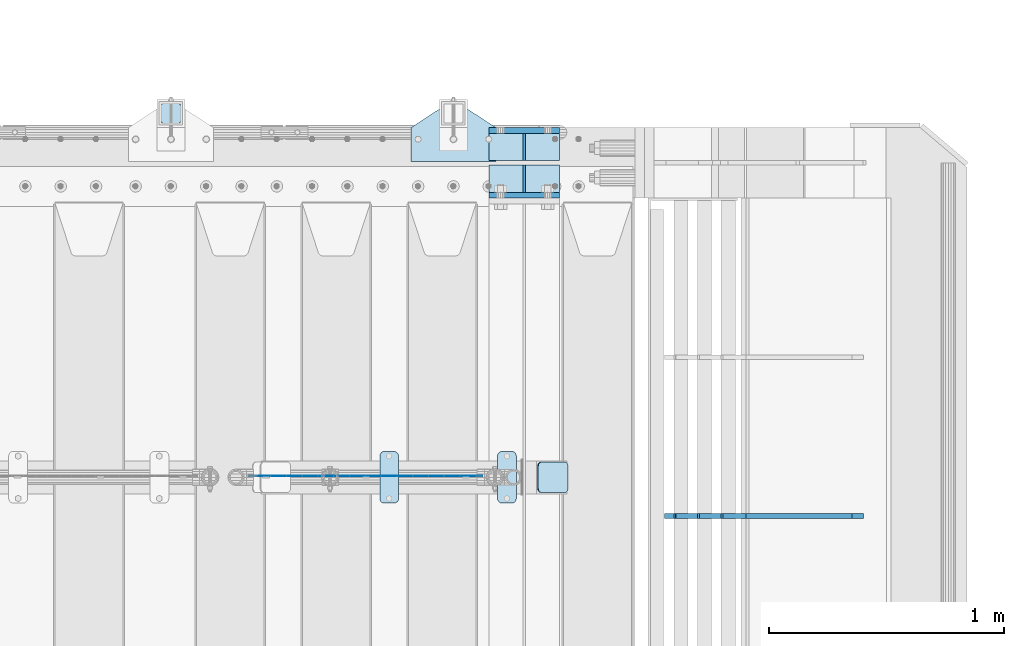
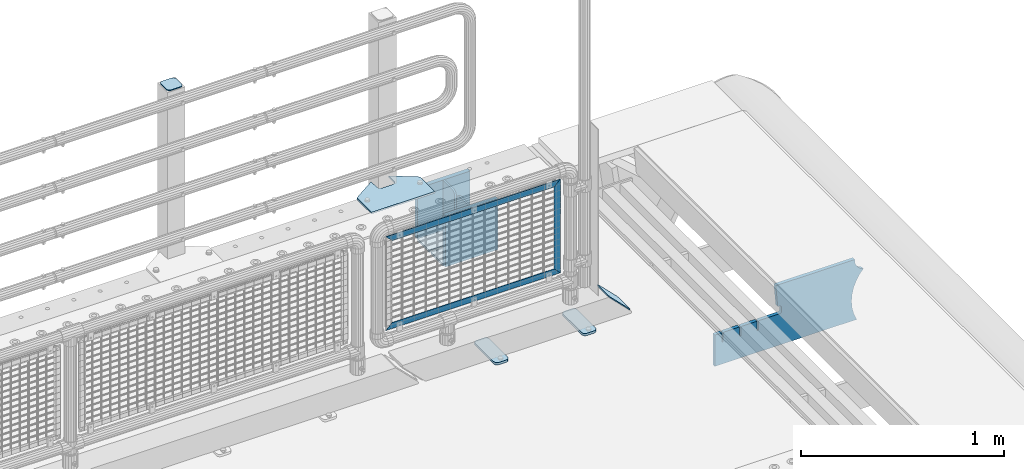
# One storey, part 251 of 270: 15 plates.
"""IFC2X3 building model written with IfcOpenShell, lengths in millimetres."""

from ifc_helpers import new_model, si_unit, frame, origin_with_axes, place, context, subcontext, project, spatial, faceted_brep, material, type_object, element, save


model = new_model("IFC2X3")

# Units and contexts
model_context = context("Model", 3, precision=1e-05, world=origin_with_axes())
body_context = subcontext(model_context, "Body", "Model", "MODEL_VIEW")
ifc_project = project(units=[si_unit("LENGTHUNIT", "METRE", prefix="MILLI"), si_unit("AREAUNIT", "SQUARE_METRE"), si_unit("VOLUMEUNIT", "CUBIC_METRE"), si_unit("MASSUNIT", "GRAM", prefix="KILO"), si_unit("TIMEUNIT", "SECOND"), si_unit("PLANEANGLEUNIT", "RADIAN"), si_unit("SOLIDANGLEUNIT", "STERADIAN"), si_unit("THERMODYNAMICTEMPERATUREUNIT", "DEGREE_CELSIUS"), si_unit("LUMINOUSINTENSITYUNIT", "LUMEN")], contexts=[model_context])

# Site, building, storey
site_placement = place(None, origin_with_axes())
site = spatial("IfcSite", under=ifc_project, at=site_placement, CompositionType="ELEMENT")
building_placement = place(site_placement, origin_with_axes())
building = spatial("IfcBuilding", under=site, at=building_placement, Name="Standard", CompositionType="ELEMENT")
storey_placement = place(building_placement, origin_with_axes())
storey = spatial("IfcBuildingStorey", under=building, at=storey_placement, Name="Undefined", CompositionType="ELEMENT", Elevation=0.0)

# Plates
ifc_material_1 = material(Name="STEEL/S355N")
plate_type_1 = type_object("IfcPlateType", PredefinedType="NOTDEFINED")
for number, where, z_axis, x_axis in (
    (1, (19768.0, -14862.5, -339.99999999999), (0.0, 0.0, 1.0), (1.0, 0.0, 0.0)),
    (2, (19768.0, -15137.5, -339.99999999999), (0.0, 0.0, 1.0), (1.0, 0.0, 0.0)),
):
    element("IfcPlate", number, at=place(storey_placement, frame(where, z_axis=z_axis, x_axis=x_axis)), inside=storey, type_object=plate_type_1, material=ifc_material_1, context=body_context, shape_type="Brep", body=[
        faceted_brep([(0.0, -12.5, 0.0), (0.0, -12.5, 305.0), (0.0, 12.5, 305.0), (0.0, 12.5, 0.0), (300.0, -12.5, 305.0), (300.0, 12.5, 305.0), (300.0, -12.5, 0.0), (300.0, 12.5, 0.0)], [[[0, 1, 2, 3]], [[1, 4, 5, 2]], [[4, 6, 7, 5]], [[6, 0, 3, 7]], [[5, 7, 3, 2]], [[6, 4, 1, 0]]]),
    ])
plate_type_2 = type_object("IfcPlateType", PredefinedType="NOTDEFINED")
for number, where, z_axis, x_axis in (
    (3, (19768.0, -14990.75, -342.99999999999), (0.0, 1.0, 0.0), (1.0, 0.0, 0.0)),
    (4, (19768.0, -15009.25, -342.99999999999), (0.0, -1.0, 0.0), (1.0, 0.0, 0.0)),
):
    element("IfcPlate", number, at=place(storey_placement, frame(where, z_axis=z_axis, x_axis=x_axis)), inside=storey, type_object=plate_type_2, material=ifc_material_1, context=body_context, shape_type="Brep", body=[
        faceted_brep([(0.0, -7.0, 0.0), (0.0, -7.0, 115.75), (0.0, 7.0, 115.75), (0.0, 7.0, 0.0), (300.0, -7.0, 115.75), (300.0, 7.0, 115.75), (300.0, -7.0, 0.0), (300.0, 7.0, 0.0)], [[[0, 1, 2, 3]], [[1, 4, 5, 2]], [[4, 6, 7, 5]], [[6, 0, 3, 7]], [[5, 7, 3, 2]], [[6, 4, 1, 0]]]),
    ])
plate_type_3 = type_object("IfcPlateType", PredefinedType="NOTDEFINED")
for number, where, z_axis, x_axis in (
    (5, (19918.0, -14990.75, -34.9999999999899), (0.0, 0.0, -1.0), (0.0, 1.0, 0.0)),
    (6, (19918.0, -15009.25, -34.9999999999899), (0.0, 0.0, -1.0), (0.0, -1.0, 0.0)),
):
    element("IfcPlate", number, at=place(storey_placement, frame(where, z_axis=z_axis, x_axis=x_axis)), inside=storey, type_object=plate_type_3, material=ifc_material_1, context=body_context, shape_type="Brep", body=[
        faceted_brep([(0.0, -5.0, 30.0), (0.0, -5.0, 301.0), (0.0, 5.0, 301.0), (0.0, 5.0, 30.0), (115.75, -5.0, 301.0), (115.75, 5.0, 301.0), (115.75, -5.0, 0.0), (115.75, 5.0, 0.0), (30.0, -5.0, 0.0), (30.0, 5.0, 0.0), (24.7905546699913, -5.0, 0.455767409633758), (24.7905546699913, 5.0, 0.455767409633758), (19.7393957002314, -5.0, 1.80922137642275), (19.7393957002314, 5.0, 1.80922137642275), (15.0, -5.0, 4.01923788646684), (15.0, 5.0, 4.01923788646684), (10.7163717094045, -5.0, 7.01866670643066), (10.7163717094045, 5.0, 7.01866670643066), (7.01866670642994, -5.0, 10.7163717094038), (7.01866670642994, 5.0, 10.7163717094038), (4.01923788646673, -5.0, 15.0), (4.01923788646673, 5.0, 15.0), (1.80922137642119, -5.0, 19.7393957002299), (1.80922137642119, 5.0, 19.7393957002299), (0.455767409632244, -5.0, 24.7905546699921), (0.455767409632244, 5.0, 24.7905546699921)], [[[0, 1, 2, 3]], [[1, 4, 5, 2]], [[4, 6, 7, 5]], [[6, 8, 9, 7]], [[8, 10, 11, 9]], [[10, 12, 13, 11]], [[12, 14, 15, 13]], [[14, 16, 17, 15]], [[16, 18, 19, 17]], [[18, 20, 21, 19]], [[20, 22, 23, 21]], [[22, 24, 25, 23]], [[24, 0, 3, 25]], [[5, 7, 9, 11, 13, 15, 17, 19, 21, 23, 25, 3, 2]], [[24, 22, 20, 18, 16, 14, 12, 10, 8, 6, 4, 1, 0]]]),
    ])
ifc_material_2 = material(Name="STEEL/S355J2")
plate_type_4 = type_object("IfcPlateType", PredefinedType="NOTDEFINED")
plate_1_placement = place(storey_placement, frame((19438.0, -14995.0, 5.00000000004911), z_axis=(0.0, 1.0, 0.0), x_axis=(1.0, 0.0, 0.0)))
element("IfcPlate", 7, at=plate_1_placement, inside=storey, type_object=plate_type_4, material=ifc_material_2, context=body_context, shape_type="Brep", body=[
    faceted_brep([(0.0, -5.0, 0.0), (2.31396552408114e-06, -5.0, 145.0), (2.31396552408114e-06, 5.0, 145.0), (0.0, 5.0, 0.0), (130.0, -5.0, 230.0), (130.0, 5.0, 230.0), (130.0, -5.0, 180.0), (130.0, 5.0, 180.0), (130.48036798992, -5.0, 175.122741949597), (130.48036798992, 5.0, 175.122741949597), (131.903011687216, -5.0, 170.432914190873), (131.903011687216, 5.0, 170.432914190873), (134.213259692435, -5.0, 166.11074417451), (134.213259692435, 5.0, 166.11074417451), (137.322330470335, -5.0, 162.322330470337), (137.322330470335, 5.0, 162.322330470337), (141.110744174512, -5.0, 159.213259692437), (141.110744174512, 5.0, 159.213259692437), (145.432914190871, -5.0, 156.903011687218), (145.432914190871, 5.0, 156.903011687218), (150.122741949595, -5.0, 155.48036798992), (150.122741949595, 5.0, 155.48036798992), (155.0, -5.0, 155.0), (155.0, 5.0, 155.0), (205.0, -5.0, 155.0), (205.0, 5.0, 155.0), (209.877258050405, -5.0, 155.48036798992), (209.877258050405, 5.0, 155.48036798992), (214.567085809129, -5.0, 156.903011687218), (214.567085809129, 5.0, 156.903011687218), (218.889255825488, -5.0, 159.213259692437), (218.889255825488, 5.0, 159.213259692437), (222.677669529665, -5.0, 162.322330470337), (222.677669529665, 5.0, 162.322330470337), (225.786740307565, -5.0, 166.11074417451), (225.786740307565, 5.0, 166.11074417451), (228.096988312784, -5.0, 170.432914190873), (228.096988312784, 5.0, 170.432914190873), (229.51963201008, -5.0, 175.122741949597), (229.51963201008, 5.0, 175.122741949597), (230.0, -5.0, 180.0), (230.0, 5.0, 180.0), (230.0, -5.0, 230.0), (230.0, 5.0, 230.0), (360.0, -5.0, 145.0), (360.0, 5.0, 145.0), (360.0, -5.0, -7.27595761418343e-12), (360.0, 5.0, -7.27595761418343e-12)], [[[0, 1, 2, 3]], [[1, 4, 5, 2]], [[4, 6, 7, 5]], [[6, 8, 9, 7]], [[8, 10, 11, 9]], [[10, 12, 13, 11]], [[12, 14, 15, 13]], [[14, 16, 17, 15]], [[16, 18, 19, 17]], [[18, 20, 21, 19]], [[20, 22, 23, 21]], [[22, 24, 25, 23]], [[24, 26, 27, 25]], [[26, 28, 29, 27]], [[28, 30, 31, 29]], [[30, 32, 33, 31]], [[32, 34, 35, 33]], [[34, 36, 37, 35]], [[36, 38, 39, 37]], [[38, 40, 41, 39]], [[40, 42, 43, 41]], [[42, 44, 45, 43]], [[44, 46, 47, 45]], [[46, 0, 3, 47]], [[5, 7, 9, 11, 13, 15, 17, 19, 21, 23, 25, 27, 29, 31, 33, 35, 37, 39, 41, 43, 45, 47, 3, 2]], [[46, 44, 42, 40, 38, 36, 34, 32, 30, 28, 26, 24, 22, 20, 18, 16, 14, 12, 10, 8, 6, 4, 1, 0]]]),
])
plate_type_5 = type_object("IfcPlateType", PredefinedType="NOTDEFINED")
plate_2_placement = place(storey_placement, frame((18462.0000000001, -14833.9999999998, 1012.50000000001), z_axis=(0.0, 1.0, 0.0), x_axis=(-1.0, 0.0, 0.0)))
element("IfcPlate", 8, at=plate_2_placement, inside=storey, type_object=plate_type_5, material=ifc_material_2, context=body_context, shape_type="Brep", body=[
    faceted_brep([(0.0, -2.5, 19.0), (0.0, -2.5, 69.0), (0.0, 2.5, 69.0), (0.0, 2.5, 19.0), (0.476369668544066, -2.5, 73.2278977451697), (0.476369668544066, 2.5, 73.2278977451697), (1.88159150985302, -2.5, 77.2437910432327), (1.88159150985302, 2.5, 77.2437910432327), (4.14520183310742, -2.5, 80.8463062353167), (4.14520183310742, 2.5, 80.8463062353167), (7.15369376468516, -2.5, 83.8547981668926), (7.15369376468516, 2.5, 83.8547981668926), (10.7562089567655, -2.5, 86.1184084901452), (10.7562089567655, 2.5, 86.1184084901452), (14.7721022548285, -2.5, 87.5236303314541), (14.7721022548285, 2.5, 87.5236303314541), (19.0, -2.5, 88.0), (19.0, 2.5, 88.0), (69.0, -2.5, 88.0), (69.0, 2.5, 88.0), (73.2278977451715, -2.5, 87.5236303314541), (73.2278977451715, 2.5, 87.5236303314541), (77.2437910432345, -2.5, 86.1184084901452), (77.2437910432345, 2.5, 86.1184084901452), (80.8463062353148, -2.5, 83.8547981668926), (80.8463062353148, 2.5, 83.8547981668926), (83.8547981668926, -2.5, 80.8463062353167), (83.8547981668926, 2.5, 80.8463062353167), (86.118408490147, -2.5, 77.2437910432345), (86.118408490147, 2.5, 77.2437910432345), (87.5236303314559, -2.5, 73.2278977451697), (87.5236303314559, 2.5, 73.2278977451697), (88.0, -2.5, 69.0), (88.0, 2.5, 69.0), (88.0, -2.5, 19.0), (88.0, 2.5, 19.0), (87.5236303314559, -2.5, 14.7721022548303), (87.5236303314559, 2.5, 14.7721022548303), (86.118408490147, -2.5, 10.7562089567673), (86.118408490147, 2.5, 10.7562089567673), (83.8547981668926, -2.5, 7.15369376468334), (83.8547981668926, 2.5, 7.15369376468334), (80.8463062353148, -2.5, 4.14520183310742), (80.8463062353148, 2.5, 4.14520183310742), (77.2437910432345, -2.5, 1.88159150985484), (77.2437910432345, 2.5, 1.88159150985484), (73.2278977451715, -2.5, 0.476369668545885), (73.2278977451715, 2.5, 0.476369668545885), (69.0, -2.5, 0.0), (69.0, 2.5, 0.0), (19.0, -2.5, 0.0), (19.0, 2.5, 0.0), (14.7721022548285, -2.5, 0.476369668545885), (14.7721022548285, 2.5, 0.476369668545885), (10.7562089567655, -2.5, 1.88159150985484), (10.7562089567655, 2.5, 1.88159150985484), (7.15369376468516, -2.5, 4.14520183310742), (7.15369376468516, 2.5, 4.14520183310742), (4.14520183310742, -2.5, 7.15369376468334), (4.14520183310742, 2.5, 7.15369376468334), (1.88159150985302, -2.5, 10.7562089567673), (1.88159150985302, 2.5, 10.7562089567673), (0.476369668544066, -2.5, 14.7721022548303), (0.476369668544066, 2.5, 14.7721022548303)], [[[0, 1, 2, 3]], [[1, 4, 5, 2]], [[4, 6, 7, 5]], [[6, 8, 9, 7]], [[8, 10, 11, 9]], [[10, 12, 13, 11]], [[12, 14, 15, 13]], [[14, 16, 17, 15]], [[16, 18, 19, 17]], [[18, 20, 21, 19]], [[20, 22, 23, 21]], [[22, 24, 25, 23]], [[24, 26, 27, 25]], [[26, 28, 29, 27]], [[28, 30, 31, 29]], [[30, 32, 33, 31]], [[32, 34, 35, 33]], [[34, 36, 37, 35]], [[36, 38, 39, 37]], [[38, 40, 41, 39]], [[40, 42, 43, 41]], [[42, 44, 45, 43]], [[44, 46, 47, 45]], [[46, 48, 49, 47]], [[48, 50, 51, 49]], [[50, 52, 53, 51]], [[52, 54, 55, 53]], [[54, 56, 57, 55]], [[56, 58, 59, 57]], [[58, 60, 61, 59]], [[60, 62, 63, 61]], [[62, 0, 3, 63]], [[5, 7, 9, 11, 13, 15, 17, 19, 21, 23, 25, 27, 29, 31, 33, 35, 37, 39, 41, 43, 45, 47, 49, 51, 53, 55, 57, 59, 61, 63, 3, 2]], [[62, 60, 58, 56, 54, 52, 50, 48, 46, 44, 42, 40, 38, 36, 34, 32, 30, 28, 26, 24, 22, 20, 18, 16, 14, 12, 10, 8, 6, 4, 1, 0]]]),
])
plate_type_6 = type_object("IfcPlateType", PredefinedType="NOTDEFINED")
plate_3_placement = place(storey_placement, frame((19805.0, -16225.5, 21.0199999999977), z_axis=(1.0, 0.0, 0.0), x_axis=(0.0, -1.0, 0.0)))
element("IfcPlate", 9, at=plate_3_placement, inside=storey, type_object=plate_type_6, material=ifc_material_2, context=body_context, shape_type="Brep", body=[
    faceted_brep([(0.0, -7.0, 20.0), (0.0, -7.0, 60.0), (0.0, 7.0, 60.0), (0.0, 7.0, 20.0), (0.384294391937146, -7.0, 63.9018064403208), (0.384294391937146, 7.0, 63.9018064403208), (1.52240934977453, -7.0, 67.6536686473009), (1.52240934977453, 7.0, 67.6536686473009), (3.37060775395003, -7.0, 71.1114046603907), (3.37060775395003, 7.0, 71.1114046603907), (5.8578643762703, -7.0, 74.1421356237297), (5.8578643762703, 7.0, 74.1421356237297), (8.88859533960931, -7.0, 76.62939224605), (8.88859533960931, 7.0, 76.62939224605), (12.3463313526991, -7.0, 78.4775906502255), (12.3463313526991, 7.0, 78.4775906502255), (16.0981935596792, -7.0, 79.6157056080629), (16.0981935596792, 7.0, 79.6157056080629), (20.0, -7.0, 80.0), (20.0, 7.0, 80.0), (200.0, -7.0, 80.0), (200.0, 7.0, 80.0), (203.901806440321, -7.0, 79.6157056080629), (203.901806440321, 7.0, 79.6157056080629), (207.653668647301, -7.0, 78.4775906502255), (207.653668647301, 7.0, 78.4775906502255), (211.111404660391, -7.0, 76.62939224605), (211.111404660391, 7.0, 76.62939224605), (214.142135623733, -7.0, 74.1421356237297), (214.142135623733, 7.0, 74.1421356237297), (216.629392246054, -7.0, 71.1114046603907), (216.629392246054, 7.0, 71.1114046603907), (218.477590650225, -7.0, 67.6536686473009), (218.477590650225, 7.0, 67.6536686473009), (219.615705608063, -7.0, 63.9018064403208), (219.615705608063, 7.0, 63.9018064403208), (220.0, -7.0, 60.0), (220.0, 7.0, 60.0), (220.0, -7.0, 20.0), (220.0, 7.0, 20.0), (219.615705608063, -7.0, 16.0981935596792), (219.615705608063, 7.0, 16.0981935596792), (218.477590650225, -7.0, 12.3463313526991), (218.477590650225, 7.0, 12.3463313526991), (216.629392246054, -7.0, 8.88859533960931), (216.629392246054, 7.0, 8.88859533960931), (214.142135623733, -7.0, 5.8578643762703), (214.142135623733, 7.0, 5.8578643762703), (211.111404660391, -7.0, 3.37060775395003), (211.111404660391, 7.0, 3.37060775395003), (207.653668647301, -7.0, 1.52240934977453), (207.653668647301, 7.0, 1.52240934977453), (203.901806440321, -7.0, 0.384294391937146), (203.901806440321, 7.0, 0.384294391937146), (200.0, -7.0, 0.0), (200.0, 7.0, 0.0), (20.0, -7.0, 0.0), (20.0, 7.0, 0.0), (16.0981935596792, -7.0, 0.384294391937146), (16.0981935596792, 7.0, 0.384294391937146), (12.3463313526991, -7.0, 1.52240934977453), (12.3463313526991, 7.0, 1.52240934977453), (8.88859533960931, -7.0, 3.37060775395003), (8.88859533960931, 7.0, 3.37060775395003), (5.8578643762703, -7.0, 5.8578643762703), (5.8578643762703, 7.0, 5.8578643762703), (3.37060775395003, -7.0, 8.88859533960931), (3.37060775395003, 7.0, 8.88859533960931), (1.52240934977453, -7.0, 12.3463313526991), (1.52240934977453, 7.0, 12.3463313526991), (0.384294391937146, -7.0, 16.0981935596792), (0.384294391937146, 7.0, 16.0981935596792)], [[[0, 1, 2, 3]], [[1, 4, 5, 2]], [[4, 6, 7, 5]], [[6, 8, 9, 7]], [[8, 10, 11, 9]], [[10, 12, 13, 11]], [[12, 14, 15, 13]], [[14, 16, 17, 15]], [[16, 18, 19, 17]], [[18, 20, 21, 19]], [[20, 22, 23, 21]], [[22, 24, 25, 23]], [[24, 26, 27, 25]], [[26, 28, 29, 27]], [[28, 30, 31, 29]], [[30, 32, 33, 31]], [[32, 34, 35, 33]], [[34, 36, 37, 35]], [[36, 38, 39, 37]], [[38, 40, 41, 39]], [[40, 42, 43, 41]], [[42, 44, 45, 43]], [[44, 46, 47, 45]], [[46, 48, 49, 47]], [[48, 50, 51, 49]], [[50, 52, 53, 51]], [[52, 54, 55, 53]], [[54, 56, 57, 55]], [[56, 58, 59, 57]], [[58, 60, 61, 59]], [[60, 62, 63, 61]], [[62, 64, 65, 63]], [[64, 66, 67, 65]], [[66, 68, 69, 67]], [[68, 70, 71, 69]], [[70, 0, 3, 71]], [[5, 7, 9, 11, 13, 15, 17, 19, 21, 23, 25, 27, 29, 31, 33, 35, 37, 39, 41, 43, 45, 47, 49, 51, 53, 55, 57, 59, 61, 63, 65, 67, 69, 71, 3, 2]], [[70, 68, 66, 64, 62, 60, 58, 56, 54, 52, 50, 48, 46, 44, 42, 40, 38, 36, 34, 32, 30, 28, 26, 24, 22, 20, 18, 16, 14, 12, 10, 8, 6, 4, 1, 0]]]),
])
plate_4_placement = place(storey_placement, frame((19305.0, -16225.5, 21.0199999999977), z_axis=(1.0, 0.0, 0.0), x_axis=(0.0, -1.0, 0.0)))
element("IfcPlate", 10, at=plate_4_placement, inside=storey, type_object=plate_type_6, material=ifc_material_2, context=body_context, shape_type="Brep", body=[
    faceted_brep([(0.0, -7.0, 20.0), (0.0, -7.0, 60.0), (0.0, 7.0, 60.0), (0.0, 7.0, 20.0), (0.384294391937146, -7.0, 63.9018064403208), (0.384294391937146, 7.0, 63.9018064403208), (1.52240934977453, -7.0, 67.6536686473009), (1.52240934977453, 7.0, 67.6536686473009), (3.37060775395003, -7.0, 71.1114046603907), (3.37060775395003, 7.0, 71.1114046603907), (5.8578643762703, -7.0, 74.1421356237297), (5.8578643762703, 7.0, 74.1421356237297), (8.88859533960931, -7.0, 76.62939224605), (8.88859533960931, 7.0, 76.62939224605), (12.3463313526991, -7.0, 78.4775906502255), (12.3463313526991, 7.0, 78.4775906502255), (16.0981935596792, -7.0, 79.6157056080629), (16.0981935596792, 7.0, 79.6157056080629), (20.0, -7.0, 80.0), (20.0, 7.0, 80.0), (200.0, -7.0, 80.0), (200.0, 7.0, 80.0), (203.901806440321, -7.0, 79.6157056080629), (203.901806440321, 7.0, 79.6157056080629), (207.653668647301, -7.0, 78.4775906502255), (207.653668647301, 7.0, 78.4775906502255), (211.111404660391, -7.0, 76.62939224605), (211.111404660391, 7.0, 76.62939224605), (214.142135623733, -7.0, 74.1421356237297), (214.142135623733, 7.0, 74.1421356237297), (216.629392246054, -7.0, 71.1114046603907), (216.629392246054, 7.0, 71.1114046603907), (218.477590650225, -7.0, 67.6536686473009), (218.477590650225, 7.0, 67.6536686473009), (219.615705608063, -7.0, 63.9018064403208), (219.615705608063, 7.0, 63.9018064403208), (220.0, -7.0, 60.0), (220.0, 7.0, 60.0), (220.0, -7.0, 20.0), (220.0, 7.0, 20.0), (219.615705608063, -7.0, 16.0981935596792), (219.615705608063, 7.0, 16.0981935596792), (218.477590650225, -7.0, 12.3463313526991), (218.477590650225, 7.0, 12.3463313526991), (216.629392246054, -7.0, 8.88859533960931), (216.629392246054, 7.0, 8.88859533960931), (214.142135623733, -7.0, 5.8578643762703), (214.142135623733, 7.0, 5.8578643762703), (211.111404660391, -7.0, 3.37060775395003), (211.111404660391, 7.0, 3.37060775395003), (207.653668647301, -7.0, 1.52240934977453), (207.653668647301, 7.0, 1.52240934977453), (203.901806440321, -7.0, 0.384294391937146), (203.901806440321, 7.0, 0.384294391937146), (200.0, -7.0, 0.0), (200.0, 7.0, 0.0), (20.0, -7.0, 0.0), (20.0, 7.0, 0.0), (16.0981935596792, -7.0, 0.384294391937146), (16.0981935596792, 7.0, 0.384294391937146), (12.3463313526991, -7.0, 1.52240934977453), (12.3463313526991, 7.0, 1.52240934977453), (8.88859533960931, -7.0, 3.37060775395003), (8.88859533960931, 7.0, 3.37060775395003), (5.8578643762703, -7.0, 5.8578643762703), (5.8578643762703, 7.0, 5.8578643762703), (3.37060775395003, -7.0, 8.88859533960931), (3.37060775395003, 7.0, 8.88859533960931), (1.52240934977453, -7.0, 12.3463313526991), (1.52240934977453, 7.0, 12.3463313526991), (0.384294391937146, -7.0, 16.0981935596792), (0.384294391937146, 7.0, 16.0981935596792)], [[[0, 1, 2, 3]], [[1, 4, 5, 2]], [[4, 6, 7, 5]], [[6, 8, 9, 7]], [[8, 10, 11, 9]], [[10, 12, 13, 11]], [[12, 14, 15, 13]], [[14, 16, 17, 15]], [[16, 18, 19, 17]], [[18, 20, 21, 19]], [[20, 22, 23, 21]], [[22, 24, 25, 23]], [[24, 26, 27, 25]], [[26, 28, 29, 27]], [[28, 30, 31, 29]], [[30, 32, 33, 31]], [[32, 34, 35, 33]], [[34, 36, 37, 35]], [[36, 38, 39, 37]], [[38, 40, 41, 39]], [[40, 42, 43, 41]], [[42, 44, 45, 43]], [[44, 46, 47, 45]], [[46, 48, 49, 47]], [[48, 50, 51, 49]], [[50, 52, 53, 51]], [[52, 54, 55, 53]], [[54, 56, 57, 55]], [[56, 58, 59, 57]], [[58, 60, 61, 59]], [[60, 62, 63, 61]], [[62, 64, 65, 63]], [[64, 66, 67, 65]], [[66, 68, 69, 67]], [[68, 70, 71, 69]], [[70, 0, 3, 71]], [[5, 7, 9, 11, 13, 15, 17, 19, 21, 23, 25, 27, 29, 31, 33, 35, 37, 39, 41, 43, 45, 47, 49, 51, 53, 55, 57, 59, 61, 63, 65, 67, 69, 71, 3, 2]], [[70, 68, 66, 64, 62, 60, 58, 56, 54, 52, 50, 48, 46, 44, 42, 40, 38, 36, 34, 32, 30, 28, 26, 24, 22, 20, 18, 16, 14, 12, 10, 8, 6, 4, 1, 0]]]),
])
ifc_material_3 = material(Name="Misc_Undefined")
plate_type_7 = type_object("IfcPlateType", PredefinedType="NOTDEFINED")
plate_5_placement = place(storey_placement, frame((18783.1100003336, -16329.5000116708, 386.520006105203), z_axis=(0.707106781186548, 0.0, -0.707106781186548), x_axis=(-0.707106781186548, 0.0, -0.707106781186548)))
element("IfcPlate", 11, at=plate_5_placement, inside=storey, type_object=plate_type_7, material=ifc_material_3, context=body_context, shape_type="Brep", body=[
    faceted_brep([(0.0, -1.5, 0.0), (-651.521057128923, -1.5, 651.521179199219), (-651.521057128924, 1.5, 651.521179199219), (0.0, 1.5, 0.0), (-651.521057128926, -1.5, 701.018676757816), (-651.521057128924, 1.5, 701.018676757813), (49.4974975585974, -1.50000000000364, 2.18278728425503e-11), (49.4974784851038, 1.49999999999818, -4.54747350886464e-11)], [[[0, 1, 2, 3]], [[1, 4, 5, 2]], [[4, 6, 7, 5]], [[6, 0, 3, 7]], [[5, 7, 3, 2]], [[6, 4, 1, 0]]]),
])
plate_6_placement = place(storey_placement, frame((19739.4999993967, -16329.5002162294, 914.520000514844), z_axis=(-0.707106781186548, 0.0, 0.707106781186548), x_axis=(-0.707106781186548, 0.0, -0.707106781186548)))
element("IfcPlate", 12, at=plate_6_placement, inside=storey, type_object=plate_type_7, material=ifc_material_3, context=body_context, shape_type="Brep", body=[
    faceted_brep([(0.0, -1.5, 0.0), (701.018554687527, -1.50000000000182, 701.018615722656), (701.018554687529, 1.49999999999818, 701.018615722656), (0.0, 1.5, 0.0), (701.018554687524, -1.50000000000182, 651.521118164061), (701.018554687525, 1.49999999999636, 651.521118164063), (49.4974975585974, -1.50000000000364, 2.18278728425503e-11), (49.4974784851038, 1.49999999999818, -4.54747350886464e-11)], [[[0, 1, 2, 3]], [[1, 4, 5, 2]], [[4, 6, 7, 5]], [[6, 0, 3, 7]], [[5, 7, 3, 2]], [[6, 4, 1, 0]]]),
])
plate_7_placement = place(storey_placement, frame((19739.4999999862, -16329.5002211987, 914.46146902851), z_axis=(0.706514791587334, 1.30000007553929e-08, -0.707698275586641), x_axis=(-0.707698275586659, 0.0, -0.706514791587316)))
element("IfcPlate", 13, at=plate_7_placement, inside=storey, type_object=plate_type_7, material=ifc_material_3, context=body_context, shape_type="Brep", body=[
    faceted_brep([(0.0, -1.5, 0.0), (397.726470947277, -1.5, 398.392700195313), (397.726470947277, 1.5, 398.392700195314), (0.0, 1.5, 0.0), (397.76788330079, -1.5, 348.895263671877), (397.76788330079, 1.5, 348.895263671877), (49.4561042785663, -1.5, -4.91127138957381e-11), (49.4561042785645, 1.5, -5.0931703299284e-11)], [[[0, 1, 2, 3]], [[1, 4, 5, 2]], [[4, 6, 7, 5]], [[6, 0, 3, 7]], [[5, 7, 3, 2]], [[6, 4, 1, 0]]]),
])
plate_type_8 = type_object("IfcPlateType", PredefinedType="NOTDEFINED")
plate_8_placement = place(storey_placement, frame((19976.192418479, -16270.5, 166.254400376567), z_axis=(0.707410512925777, 0.0, -0.706802918925841), x_axis=(0.0, -1.0, 0.0)))
element("IfcPlate", 14, at=plate_8_placement, inside=storey, type_object=plate_type_8, material=ifc_material_2, context=body_context, shape_type="Brep", body=[
    faceted_brep([(0.0, -2.50000000000182, 20.0), (0.0, -2.50000000000182, 158.926651000977), (0.0, 2.49999999999818, 158.926651000977), (0.0, 2.49999999999818, 20.0), (0.384294391935327, -2.5, 162.828457441299), (0.384294391935327, 2.49999999999818, 162.828457441301), (1.52240934977453, -2.5, 166.580319648279), (1.52240934977453, 2.49999999999818, 166.580319648278), (3.37060775394821, -2.5, 170.038055661367), (3.37060775394821, 2.49999999999818, 170.038055661369), (5.85786437626848, -2.5, 173.068786624706), (5.85786437626848, 2.49999999999818, 173.068786624708), (8.88859533960749, -2.50000000000182, 175.556043247028), (8.88859533960749, 2.49999999999818, 175.556043247028), (12.3463313526991, -2.50000000000182, 177.404241651202), (12.3463313526991, 2.5, 177.404241651202), (16.0981935596774, -2.50000000000182, 178.542356609043), (16.0981935596774, 2.5, 178.542356609041), (20.0, -2.5, 178.926651000975), (20.0, 2.49999999999818, 178.926651000977), (110.0, -2.5, 178.926651000975), (110.0, 2.49999999999818, 178.926651000977), (113.901806440321, -2.50000000000182, 178.542356609043), (113.901806440321, 2.5, 178.542356609041), (117.653668647301, -2.50000000000182, 177.404241651202), (117.653668647301, 2.5, 177.404241651202), (121.111404660391, -2.50000000000182, 175.556043247028), (121.111404660391, 2.49999999999818, 175.556043247028), (124.14213562373, -2.5, 173.068786624706), (124.14213562373, 2.49999999999818, 173.068786624708), (126.62939224605, -2.5, 170.038055661367), (126.62939224605, 2.49999999999818, 170.038055661369), (128.477590650225, -2.5, 166.580319648279), (128.477590650225, 2.49999999999818, 166.580319648278), (129.615705608063, -2.5, 162.828457441299), (129.615705608063, 2.49999999999818, 162.828457441301), (130.0, -2.50000000000182, 158.926651000977), (130.0, 2.49999999999818, 158.926651000977), (130.0, -2.50000000000182, 20.0), (130.0, 2.49999999999818, 20.0), (129.615705608063, -2.50000000000182, 16.0981935596792), (129.615705608063, 2.49999999999818, 16.0981935596792), (128.477590650225, -2.5, 12.3463313526991), (128.477590650225, 2.49999999999818, 12.3463313526991), (126.62939224605, -2.5, 8.88859533960749), (126.62939224605, 2.49999999999818, 8.88859533960931), (124.14213562373, -2.50000000000182, 5.8578643762703), (124.14213562373, 2.49999999999818, 5.8578643762703), (121.111404660391, -2.50000000000182, 3.37060775394821), (121.111404660391, 2.5, 3.37060775394821), (117.653668647301, -2.50000000000182, 1.52240934977453), (117.653668647301, 2.49999999999818, 1.52240934977635), (113.901806440321, -2.5, 0.384294391935327), (113.901806440321, 2.5, 0.384294391935327), (110.0, -2.50000000000182, 1.81898940354586e-12), (110.0, 2.5, -1.81898940354586e-12), (20.0, -2.50000000000182, 1.81898940354586e-12), (20.0, 2.5, -1.81898940354586e-12), (16.0981935596774, -2.5, 0.384294391935327), (16.0981935596774, 2.5, 0.384294391935327), (12.3463313526991, -2.50000000000182, 1.52240934977453), (12.3463313526991, 2.49999999999818, 1.52240934977635), (8.88859533960749, -2.50000000000182, 3.37060775394821), (8.88859533960749, 2.5, 3.37060775394821), (5.85786437626848, -2.50000000000182, 5.8578643762703), (5.85786437626848, 2.49999999999818, 5.8578643762703), (3.37060775394821, -2.5, 8.88859533960749), (3.37060775394821, 2.49999999999818, 8.88859533960931), (1.52240934977453, -2.5, 12.3463313526991), (1.52240934977453, 2.49999999999818, 12.3463313526991), (0.384294391935327, -2.50000000000182, 16.0981935596792), (0.384294391935327, 2.49999999999818, 16.0981935596792)], [[[0, 1, 2, 3]], [[1, 4, 5, 2]], [[4, 6, 7, 5]], [[6, 8, 9, 7]], [[8, 10, 11, 9]], [[10, 12, 13, 11]], [[12, 14, 15, 13]], [[14, 16, 17, 15]], [[16, 18, 19, 17]], [[18, 20, 21, 19]], [[20, 22, 23, 21]], [[22, 24, 25, 23]], [[24, 26, 27, 25]], [[26, 28, 29, 27]], [[28, 30, 31, 29]], [[30, 32, 33, 31]], [[32, 34, 35, 33]], [[34, 36, 37, 35]], [[36, 38, 39, 37]], [[38, 40, 41, 39]], [[40, 42, 43, 41]], [[42, 44, 45, 43]], [[44, 46, 47, 45]], [[46, 48, 49, 47]], [[48, 50, 51, 49]], [[50, 52, 53, 51]], [[52, 54, 55, 53]], [[54, 56, 57, 55]], [[56, 58, 59, 57]], [[58, 60, 61, 59]], [[60, 62, 63, 61]], [[62, 64, 65, 63]], [[64, 66, 67, 65]], [[66, 68, 69, 67]], [[68, 70, 71, 69]], [[70, 0, 3, 71]], [[5, 7, 9, 11, 13, 15, 17, 19, 21, 23, 25, 27, 29, 31, 33, 35, 37, 39, 41, 43, 45, 47, 49, 51, 53, 55, 57, 59, 61, 63, 65, 67, 69, 71, 3, 2]], [[70, 68, 66, 64, 62, 60, 58, 56, 54, 52, 50, 48, 46, 44, 42, 40, 38, 36, 34, 32, 30, 28, 26, 24, 22, 20, 18, 16, 14, 12, 10, 8, 6, 4, 1, 0]]]),
])
plate_type_9 = type_object("IfcPlateType", PredefinedType="NOTDEFINED")
plate_9_placement = place(storey_placement, frame((21355.9182339676, -16500.0007171631, -374.002067436516), z_axis=(0.0, 0.0, 1.0), x_axis=(-1.0, 0.0, 0.0)))
element("IfcPlate", 15, at=plate_9_placement, inside=storey, type_object=plate_type_9, material=ifc_material_1, context=body_context, shape_type="Brep", body=[
    faceted_brep([(801.919404066546, -10.0, 188.0), (801.919404066546, 10.0, 188.0), (801.919404066546, 10.0, 132.002067436952), (801.919404066546, -10.0, 132.002067436952), (793.919404066546, 10.0, 132.002067436952), (793.919404066546, -10.0, 132.002067436952), (793.919404066546, 10.0, 180.002067436952), (793.919404066546, -10.0, 180.002067436952), (793.527856196906, 10.0, 182.474203391951), (793.527856196906, -10.0, 182.474203391951), (792.391540021545, 10.0, 184.704349455291), (792.391540021545, -10.0, 184.704349455291), (790.621686084887, 10.0, 186.474203391951), (790.621686084887, -10.0, 186.474203391951), (788.391540021545, 10.0, 187.610519567313), (788.391540021545, -10.0, 187.610519567313), (785.919404066546, -10.0, 188.002067436952), (785.919404066546, 10.0, 188.0), (841.0, -10.0, 188.0), (841.0, -10.0, 0.0), (841.0, 10.0, 0.0), (841.0, 10.0, 188.0), (33.3619566735979, -10.0, 0.0), (33.3619566735979, 10.0, 0.0), (36.2350612208174, -10.0, 4.68848050267013), (36.2350612208174, 10.0, 4.68848050267013), (51.4877592159428, -10.0, 41.5117508652784), (51.4877592159428, 10.0, 41.5117508652784), (60.792242588137, -10.0, 80.2677133162964), (60.792242588137, 10.0, 80.2677133162964), (63.9194040769726, -10.0, 120.002067436515), (63.9194040769726, 10.0, 120.002067436515), (60.792242588137, -10.0, 159.736421556734), (60.792242588137, 10.0, 159.736421556734), (51.4877592159428, -10.0, 198.492384007752), (51.4877592159428, 10.0, 198.492384007752), (36.2350612208174, -10.0, 235.31565437036), (36.2350612208174, 10.0, 235.31565437036), (15.4097206482074, -10.0, 269.299521518803), (15.4097206482074, 10.0, 269.299521518803), (-3.35474438098754, -10.0, 291.269887256574), (-3.35474438098754, 10.0, 291.269887256574), (-2.36881039375294, -10.0, 291.426043859339), (-2.36881039375294, 10.0, 291.426043859339), (17.1449676604716, -10.0, 301.368810393754), (17.1449676604716, 10.0, 301.368810393754), (32.6311896062471, -10.0, 316.855032339527), (32.6311896062471, 10.0, 316.855032339527), (42.573956140659, -10.0, 336.368810393754), (42.573956140659, 10.0, 336.368810393754), (46.0, -10.0, 358.0), (46.0, 10.0, 358.0), (45.0495205499174, -10.0, 364.001091067617), (45.0495205499174, 10.0, 364.001091067617), (495.040008544922, -10.0, 364.010009765625), (495.040008544922, 10.0, 364.010009765625), (483.600036621094, -10.0, 233.759994506836), (483.600036621094, 10.0, 233.759994506836), (472.0, -10.0, 233.759994506836), (472.0, 10.0, 233.759994506836), (468.909830056251, -10.0, 233.270559669787), (468.909830056251, 10.0, 233.270559669787), (466.122147477075, -10.0, 231.850164450585), (466.122147477075, 10.0, 231.850164450585), (463.909830056251, -10.0, 229.637847029761), (463.909830056251, 10.0, 229.637847029761), (462.489434837047, -10.0, 226.850164450585), (462.489434837047, 10.0, 226.850164450585), (462.0, -10.0, 223.759994506836), (462.0, 10.0, 223.759994506836), (462.0, -10.0, 198.0), (462.0, 10.0, 198.0), (462.489434837047, -10.0, 194.909830056251), (462.489434837047, 10.0, 194.909830056251), (463.909830056251, -10.0, 192.122147477075), (463.909830056251, 10.0, 192.122147477075), (466.122147477075, -10.0, 189.909830056251), (466.122147477075, 10.0, 189.909830056251), (468.909830056251, -10.0, 188.489434837048), (468.909830056251, 10.0, 188.489434837048), (472.0, -10.0, 188.0), (472.0, 10.0, 188.0), (585.919404066546, -10.0, 188.002067436952), (585.919404066546, 10.0, 188.0), (588.391540021545, -10.0, 187.610519567313), (588.391540021545, 10.0, 187.610519567313), (590.621686084887, -10.0, 186.474203391951), (590.621686084887, 10.0, 186.474203391951), (592.391540021545, -10.0, 184.704349455291), (592.391540021545, 10.0, 184.704349455291), (593.527856196906, -10.0, 182.474203391951), (593.527856196906, 10.0, 182.474203391951), (593.919404066546, -10.0, 180.002067436952), (593.919404066546, 10.0, 180.002067436952), (593.919404066546, -10.0000000000036, 132.002067436952), (593.919404066546, 10.0, 132.002067436952), (601.919404066546, -10.0000000000036, 132.002067436952), (601.919404066546, 10.0, 132.002067436952), (601.919404066546, -10.0, 188.0), (601.919404066546, 10.0, 188.0), (685.919404066546, -10.0, 188.002067436952), (685.919404066546, 10.0, 188.0), (688.391540021545, -10.0, 187.610519567313), (688.391540021545, 10.0, 187.610519567313), (690.621686084887, -10.0, 186.474203391951), (690.621686084887, 10.0, 186.474203391951), (692.391540021545, -10.0, 184.704349455291), (692.391540021545, 10.0, 184.704349455291), (693.527856196906, -10.0, 182.474203391951), (693.527856196906, 10.0, 182.474203391951), (693.919404066546, -10.0, 180.002067436952), (693.919404066546, 10.0, 180.002067436952), (693.919404066546, -10.0, 132.002067436952), (693.919404066546, 10.0, 132.002067436952), (701.919404066546, -10.0, 132.002067436952), (701.919404066546, 10.0, 132.002067436952), (701.919404066546, -10.0, 188.0), (701.919404066546, 10.0, 188.0)], [[[0, 1, 2, 3]], [[3, 2, 4, 5]], [[5, 4, 6, 7]], [[7, 6, 8, 9]], [[9, 8, 10, 11]], [[11, 10, 12, 13]], [[13, 12, 14, 15]], [[16, 15, 14, 17]], [[18, 19, 20, 21]], [[20, 19, 22, 23]], [[22, 24, 25, 23]], [[26, 27, 25, 24]], [[28, 29, 27, 26]], [[30, 31, 29, 28]], [[32, 33, 31, 30]], [[34, 35, 33, 32]], [[36, 37, 35, 34]], [[38, 39, 37, 36]], [[39, 38, 40, 41]], [[40, 42, 43, 41]], [[44, 45, 43, 42]], [[46, 47, 45, 44]], [[48, 49, 47, 46]], [[50, 51, 49, 48]], [[52, 53, 51, 50]], [[54, 55, 53, 52]], [[54, 56, 57, 55]], [[56, 58, 59, 57]], [[58, 60, 61, 59]], [[60, 62, 63, 61]], [[62, 64, 65, 63]], [[64, 66, 67, 65]], [[66, 68, 69, 67]], [[68, 70, 71, 69]], [[70, 72, 73, 71]], [[72, 74, 75, 73]], [[74, 76, 77, 75]], [[76, 78, 79, 77]], [[78, 80, 81, 79]], [[81, 80, 82, 83]], [[82, 84, 85, 83]], [[86, 87, 85, 84]], [[88, 89, 87, 86]], [[90, 91, 89, 88]], [[92, 93, 91, 90]], [[94, 95, 93, 92]], [[96, 97, 95, 94]], [[98, 99, 97, 96]], [[99, 98, 100, 101]], [[100, 102, 103, 101]], [[104, 105, 103, 102]], [[106, 107, 105, 104]], [[108, 109, 107, 106]], [[110, 111, 109, 108]], [[112, 113, 111, 110]], [[114, 115, 113, 112]], [[116, 117, 115, 114]], [[117, 116, 16, 17]], [[12, 10, 8, 6, 4, 2, 1, 21, 20, 23, 25, 27, 29, 31, 33, 35, 37, 39, 41, 43, 45, 47, 49, 51, 53, 55, 57, 59, 61, 63, 65, 67, 69, 71, 73, 75, 77, 79, 81, 83, 85, 87, 89, 91, 93, 95, 97, 99, 101, 103, 105, 107, 109, 111, 113, 115, 117, 17, 14]], [[18, 21, 1, 0]], [[116, 114, 112, 110, 108, 106, 104, 102, 100, 98, 96, 94, 92, 90, 88, 86, 84, 82, 80, 78, 76, 74, 72, 70, 68, 66, 64, 62, 60, 58, 56, 54, 52, 50, 48, 46, 44, 42, 40, 38, 36, 34, 32, 30, 28, 26, 24, 22, 19, 18, 0, 3, 5, 7, 9, 11, 13, 15, 16]]]),
])

save(model, "model.ifc")
